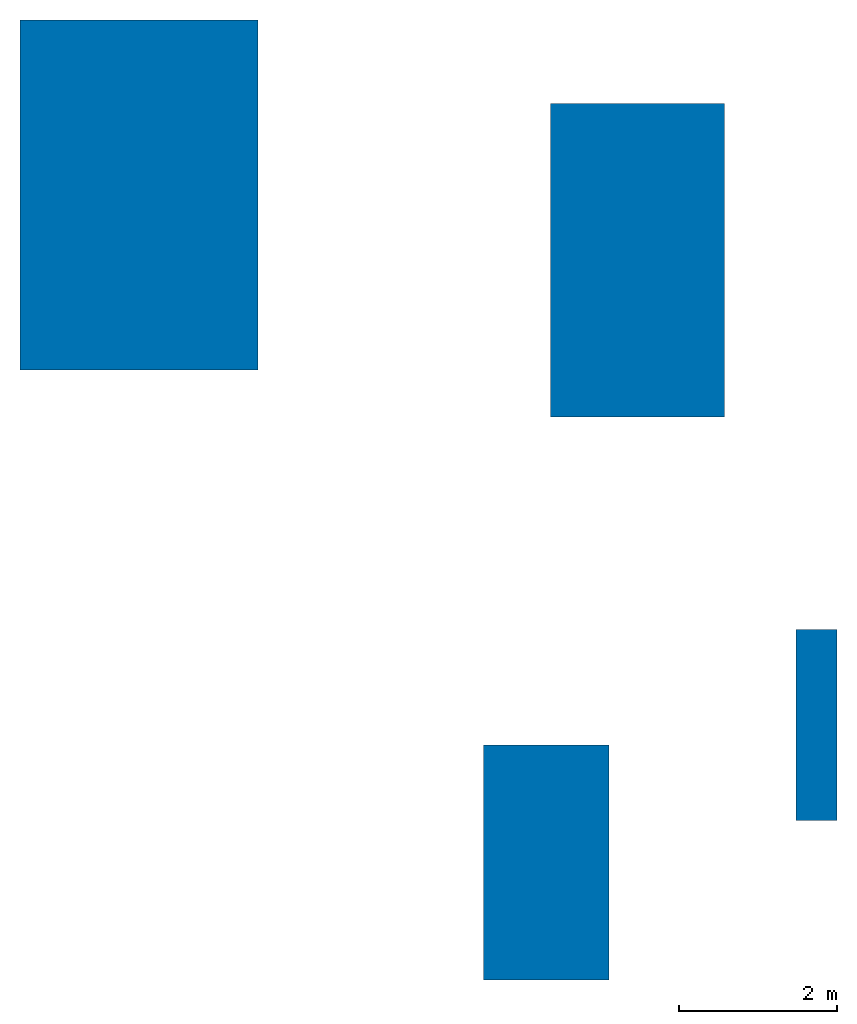
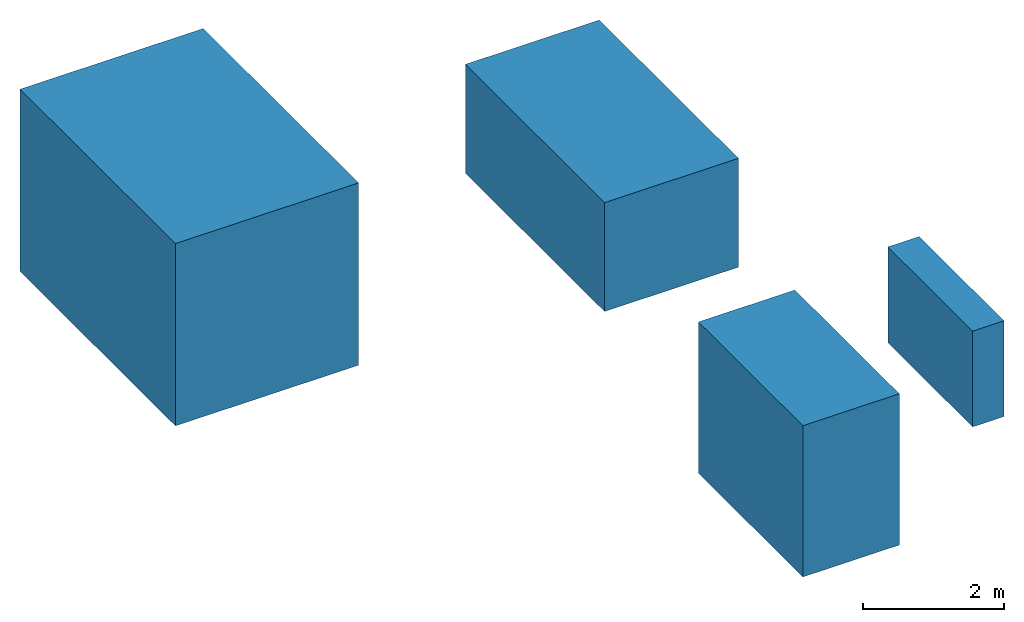
# One storey: 4 walls.
"""IFC4X3 building model written with IfcOpenShell, lengths in metres."""

from ifc_helpers import new_model, entity, si_unit, converted_unit, frame, origin_with_axes, origin_2d_with_axis, place, context, subcontext, project, spatial, rectangle, polygons, material, layer, layer_set, constituent, constituent_set, material_profile, profile_set, element, save


model = new_model("IFC4X3")

# Units and contexts
model_context = context("Model", 3, precision=1e-05, world=origin_with_axes())
plan_context = context("Plan", 2, precision=1e-05, world=origin_2d_with_axis())
body_context = subcontext(model_context, "Body", "Model", "MODEL_VIEW")
ifc_project = project(units=[si_unit("VOLUMEUNIT", "CUBIC_METRE"), si_unit("LENGTHUNIT", "METRE"), converted_unit("PLANEANGLEUNIT", "degree", entity("IfcReal", 0.0174532925199433), si_unit("PLANEANGLEUNIT", "RADIAN"), dimensions=[0, 0, 0, 0, 0, 0, 0]), si_unit("AREAUNIT", "SQUARE_METRE")], contexts=[model_context, plan_context])

# Site, building, storey
site_placement = place(None, origin_with_axes())
site = spatial("IfcSite", under=ifc_project, at=site_placement)
building_placement = place(site_placement, origin_with_axes())
building = spatial("IfcBuilding", under=site, at=building_placement, Name="Building")
storey_placement = place(building_placement, origin_with_axes())
storey = spatial("IfcBuildingStorey", under=building, at=storey_placement, Name="Storey")

# Walls
ifc_material_1 = material(Name="Material1")
ifc_layer_1 = layer(ifc_material_1, 0.100000001490116)
ifc_material_2 = material(Name="Material2")
ifc_layer_2 = layer(ifc_material_2, 1.0)
ifc_layer_set = layer_set([ifc_layer_1, ifc_layer_2])
wall_1_placement = place(storey_placement, frame((-3.30210399627686, 3.430739402771, 1.58232307434082), z_axis=(0.0, 0.0, 1.0), x_axis=(1.0, 0.0, 0.0)))
element("IfcWall", 1, at=wall_1_placement, inside=storey, material=ifc_layer_set, Name="Wall_w_material", PredefinedType="ELEMENTEDWALL", context=body_context, shape_type="Tessellation", body=[
    polygons([(-1.50429821014404, -2.21032333374023, -1.58232307434082), (-1.50429821014404, -2.21032333374023, 1.58232307434082), (-1.50429821014404, 2.21032333374023, -1.58232307434082), (-1.50429821014404, 2.21032333374023, 1.58232307434082), (1.50429821014404, -2.21032333374023, -1.58232307434082), (1.50429821014404, -2.21032333374023, 1.58232307434082), (1.50429821014404, 2.21032333374023, -1.58232307434082), (1.50429821014404, 2.21032333374023, 1.58232307434082)], [[[1, 2, 4, 3]], [[3, 4, 8, 7]], [[7, 8, 6, 5]], [[5, 6, 2, 1]], [[3, 7, 5, 1]], [[8, 4, 2, 6]]]),
])
wall_2_placement = place(storey_placement, frame((2.99556398391724, 2.60442471504211, 0.945196866989136), z_axis=(0.0, 0.0, 1.0), x_axis=(1.0, 0.0, 0.0)))
element("IfcWall", 2, at=wall_2_placement, inside=storey, material=ifc_material_1, Name="Wall_w_single_material", PredefinedType="ELEMENTEDWALL", context=body_context, shape_type="Tessellation", body=[
    polygons([(-1.09912824630737, -1.97994208335876, -0.945196866989136), (-1.09912824630737, -1.97994208335876, 0.945196866989136), (-1.09912824630737, 1.97994208335876, -0.945196866989136), (-1.09912824630737, 1.97994208335876, 0.945196866989136), (1.09912824630737, -1.97994208335876, -0.945196866989136), (1.09912824630737, -1.97994208335876, 0.945196866989136), (1.09912824630737, 1.97994208335876, -0.945196866989136), (1.09912824630737, 1.97994208335876, 0.945196866989136)], [[[1, 2, 4, 3]], [[3, 4, 8, 7]], [[7, 8, 6, 5]], [[5, 6, 2, 1]], [[3, 7, 5, 1]], [[8, 4, 2, 6]]]),
])
ifc_material_profile = material_profile(ifc_material_1, rectangle(XDim=0.5, YDim=0.5), Name="ProfileMaterial")
ifc_profile_set = profile_set([ifc_material_profile], Name="ProfileSetMaterial")
wall_3_placement = place(storey_placement, frame((1.83938837051392, -4.99963617324829, 1.31327795982361), z_axis=(0.0, 0.0, 1.0), x_axis=(1.0, 0.0, 0.0)))
element("IfcWall", 3, at=wall_3_placement, inside=storey, material=ifc_profile_set, Name="Wall_w_profile_material", PredefinedType="ELEMENTEDWALL", context=body_context, shape_type="Tessellation", body=[
    polygons([(-0.79203462600708, -1.48569869995117, -1.31327795982361), (-0.79203462600708, -1.48569869995117, 1.31327795982361), (-0.79203462600708, 1.48569869995117, -1.31327795982361), (-0.79203462600708, 1.48569869995117, 1.31327795982361), (0.79203462600708, -1.48569869995117, -1.31327795982361), (0.79203462600708, -1.48569869995117, 1.31327795982361), (0.79203462600708, 1.48569869995117, -1.31327795982361), (0.79203462600708, 1.48569869995117, 1.31327795982361)], [[[1, 2, 4, 3]], [[3, 4, 8, 7]], [[7, 8, 6, 5]], [[5, 6, 2, 1]], [[3, 7, 5, 1]], [[8, 4, 2, 6]]]),
])
ifc_constituent_1 = constituent(ifc_material_1, fraction=0.400000005960464)
ifc_constituent_2 = constituent(ifc_material_2, fraction=0.600000023841858)
ifc_constituent_set = constituent_set(constituents=[ifc_constituent_1, ifc_constituent_2])
wall_4_placement = place(storey_placement, frame((5.25593996047974, -3.26383543014526, 0.831313371658325), z_axis=(0.0, 0.0, 1.0), x_axis=(1.0, 0.0, 0.0)))
element("IfcWall", 4, at=wall_4_placement, inside=storey, material=ifc_constituent_set, Name="Wall_w_material", PredefinedType="ELEMENTEDWALL", context=body_context, shape_type="Tessellation", body=[
    polygons([(-0.257631778717041, -1.20645189285278, -0.831313371658325), (-0.257631778717041, -1.20645189285278, 0.831313371658325), (-0.257631778717041, 1.20645189285278, -0.831313371658325), (-0.257631778717041, 1.20645189285278, 0.831313371658325), (0.257631778717041, -1.20645189285278, -0.831313371658325), (0.257631778717041, -1.20645189285278, 0.831313371658325), (0.257631778717041, 1.20645189285278, -0.831313371658325), (0.257631778717041, 1.20645189285278, 0.831313371658325)], [[[1, 2, 4, 3]], [[3, 4, 8, 7]], [[7, 8, 6, 5]], [[5, 6, 2, 1]], [[3, 7, 5, 1]], [[8, 4, 2, 6]]]),
])

save(model, "model.ifc")
